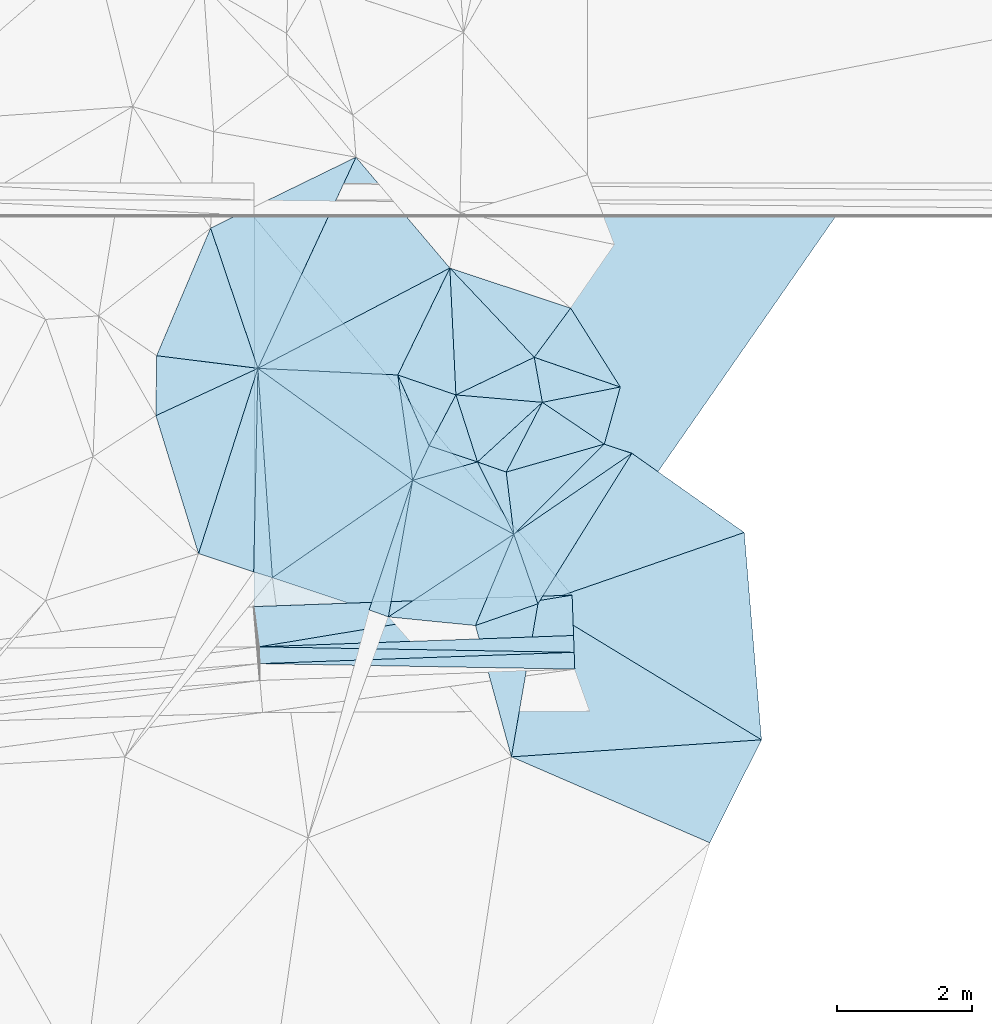
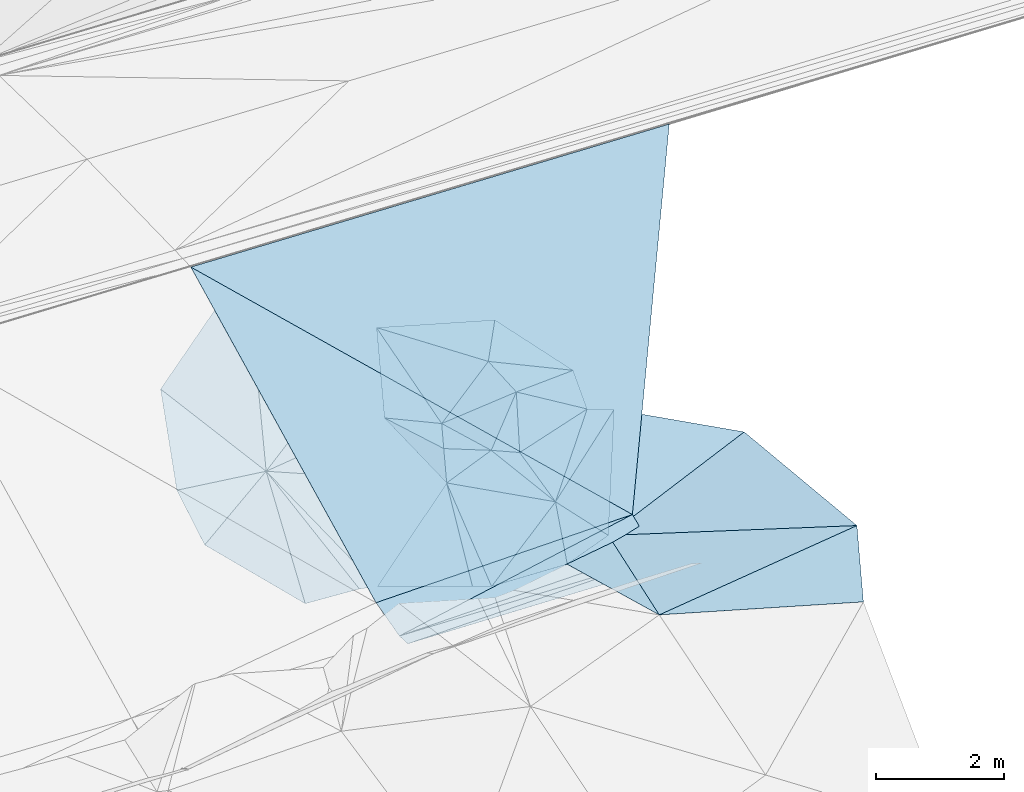
# One storey, part 105 of 275: 46 plates.
"""IFC2X3 building model written with IfcOpenShell, lengths in millimetres."""

from ifc_helpers import new_model, si_unit, frame, origin_with_axes, place, context, subcontext, project, spatial, polyline, outline, extrude, material, type_object, element, save


model = new_model("IFC2X3")

# Units and contexts
model_context = context("Model", 3, precision=1e-05, world=origin_with_axes())
body_context = subcontext(model_context, "Body", "Model", "MODEL_VIEW")
ifc_project = project(units=[si_unit("LENGTHUNIT", "METRE", prefix="MILLI"), si_unit("AREAUNIT", "SQUARE_METRE"), si_unit("VOLUMEUNIT", "CUBIC_METRE"), si_unit("MASSUNIT", "GRAM", prefix="KILO"), si_unit("TIMEUNIT", "SECOND"), si_unit("PLANEANGLEUNIT", "RADIAN"), si_unit("SOLIDANGLEUNIT", "STERADIAN"), si_unit("THERMODYNAMICTEMPERATUREUNIT", "DEGREE_CELSIUS"), si_unit("LUMINOUSINTENSITYUNIT", "LUMEN")], contexts=[model_context])

# Site, building, storey
site_placement = place(None, origin_with_axes())
site = spatial("IfcSite", under=ifc_project, at=site_placement, CompositionType="ELEMENT")
building_placement = place(site_placement, origin_with_axes())
building = spatial("IfcBuilding", under=site, at=building_placement, Name="Undefined", CompositionType="ELEMENT")
storey_placement = place(building_placement, origin_with_axes())
storey = spatial("IfcBuildingStorey", under=building, at=storey_placement, Name="Undefined", CompositionType="ELEMENT", Elevation=0.0)

# Plates
ifc_material = material()
plate_type_1 = type_object("IfcPlateType", PredefinedType="NOTDEFINED")
for number, where, z_axis, x_axis, name in (
    (1, (-34071.6223513532, 53401.6972829406, 44876.9950661578), (-0.0160094213727452, -0.000576917723859668, -0.999871674562916), (0.999223107997821, 0.0360075830405847, -0.0160198129436686), "00_PR"),
    (2, (-34080.6255523852, 53651.5352707034, 44876.9950644375), (-0.0160094213727452, -0.000576917723859668, -0.999871674562916), (0.999223107997821, 0.0360075830405847, -0.0160198129436686), "00_PR"),
    (3, (-29400.480336561, 53570.0245866541, 44802.1060646586), (-0.0160094213727452, -0.000576917723859668, -0.999871674562916), (-0.999223107998599, -0.0360075830192284, 0.0160198129431634), "00_PR"),
):
    element("IfcPlate", number, at=place(storey_placement, frame(where, z_axis=z_axis, x_axis=x_axis)), inside=storey, type_object=plate_type_1, material=ifc_material, Name=name, context=body_context, shape_type="SweptSolid", body=[
        extrude(outline(polyline([(0.0, 0.0), (4674.77392578125, -1.64072844199836e-08), (4674.77392578125, 250.000152587891), (0.0, 0.0)])), frame((-8.85201319254618e-08, 2.18876761149539e-07, -0.5000001331573), z_axis=(0.0, 0.0, 1.0), x_axis=(1.0, 0.0, 0.0)), (0.0, 0.0, 1.0), 1.0),
    ])
plate_type_2 = type_object("IfcPlateType", PredefinedType="NOTDEFINED")
plate_1_placement = place(storey_placement, frame((-34980.2329923072, 55035.6224155417, 44969.5172339417), z_axis=(0.231715827225218, 0.118649041809112, -0.965520678334293), x_axis=(-0.294650401531894, 0.954469308654738, 0.0465776739784269)))
element("IfcPlate", 4, at=plate_1_placement, inside=storey, type_object=plate_type_2, material=ifc_material, Name="00", context=body_context, shape_type="SweptSolid", body=[
    extrude(outline(polyline([(0.0, 0.0), (2146.95141601563, -6.11908035352826e-09), (2392.13623046875, 1712.36218261719), (0.0, 0.0)])), frame((-8.85201319254618e-08, 2.18876761149539e-07, -0.5000001331573), z_axis=(0.0, 0.0, 1.0), x_axis=(1.0, 0.0, 0.0)), (0.0, 0.0, 1.0), 1.0),
])
plate_type_3 = type_object("IfcPlateType", PredefinedType="NOTDEFINED")
plate_2_placement = place(storey_placement, frame((-28543.1043825455, 56525.7265106292, 45519.5109293594), z_axis=(0.115885451345455, 0.172720075435549, -0.978130020860212), x_axis=(-0.518015561419789, -0.829724566261981, -0.207887042088507)))
element("IfcPlate", 5, at=plate_2_placement, inside=storey, type_object=plate_type_3, material=ifc_material, Name="00", context=body_context, shape_type="SweptSolid", body=[
    extrude(outline(polyline([(0.0, 0.0), (2693.7705078125, 6.66477717459202e-09), (1992.96850585938, 851.279296875), (0.0, 0.0)])), frame((-8.85201319254618e-08, 2.18876761149539e-07, -0.5000001331573), z_axis=(0.0, 0.0, 1.0), x_axis=(1.0, 0.0, 0.0)), (0.0, 0.0, 1.0), 1.0),
])
plate_type_4 = type_object("IfcPlateType", PredefinedType="NOTDEFINED")
plate_3_placement = place(storey_placement, frame((-31246.6210959836, 59277.6440215739, 46359.541500599), z_axis=(0.17469677616327, 0.358633115088476, -0.916986000525687), x_axis=(0.678853557676361, -0.718442221787708, -0.151652962987508)))
element("IfcPlate", 6, at=plate_3_placement, inside=storey, type_object=plate_type_4, material=ifc_material, Name="00", context=body_context, shape_type="SweptSolid", body=[
    extrude(outline(polyline([(0.0, 0.0), (1846.32067871094, 2.47382558882236e-10), (1524.1123046875, 1324.94592285156), (0.0, 0.0)])), frame((-8.85201319254618e-08, 2.18876761149539e-07, -0.5000001331573), z_axis=(0.0, 0.0, 1.0), x_axis=(1.0, 0.0, 0.0)), (0.0, 0.0, 1.0), 1.0),
])
plate_type_5 = type_object("IfcPlateType", PredefinedType="NOTDEFINED")
plate_4_placement = place(storey_placement, frame((-29872.8224917118, 57282.821722104, 45859.5295280581), z_axis=(-0.0500565715002064, 0.334876283704204, -0.94093156725774), x_axis=(0.80520797630461, -0.54383905544036, -0.23638780990815)))
element("IfcPlate", 7, at=plate_4_placement, inside=storey, type_object=plate_type_5, material=ifc_material, Name="00", context=body_context, shape_type="SweptSolid", body=[
    extrude(outline(polyline([(0.0, 0.0), (1142.19091796875, 2.5465851649642e-09), (211.085556030273, 1196.67993164063), (0.0, 0.0)])), frame((-8.85201319254618e-08, 2.18876761149539e-07, -0.5000001331573), z_axis=(0.0, 0.0, 1.0), x_axis=(1.0, 0.0, 0.0)), (0.0, 0.0, 1.0), 1.0),
])
plate_type_6 = type_object("IfcPlateType", PredefinedType="NOTDEFINED")
plate_5_placement = place(storey_placement, frame((-34080.6327561477, 53651.7587413823, 44877.0478344557), z_axis=(-0.030423128041603, 0.446361798580259, -0.894335271611469), x_axis=(0.985509466993373, 0.162771131022706, 0.0477142470550187)))
element("IfcPlate", 8, at=plate_5_placement, inside=storey, type_object=plate_type_6, material=ifc_material, Name="00_PR", context=body_context, shape_type="SweptSolid", body=[
    extrude(outline(polyline([(0.0, 0.0), (4717.89892578125, -4.75847627967596e-09), (4627.2802734375, 664.671203613281), (0.0, 0.0)])), frame((-8.85201319254618e-08, 2.18876761149539e-07, -0.5000001331573), z_axis=(0.0, 0.0, 1.0), x_axis=(1.0, 0.0, 0.0)), (0.0, 0.0, 1.0), 1.0),
])
plate_type_7 = type_object("IfcPlateType", PredefinedType="NOTDEFINED")
plate_6_placement = place(storey_placement, frame((-34158.2967206193, 54249.3492435354, 45177.0475667269), z_axis=(-0.0302235307072089, 0.445309090165948, -0.894866667390828), x_axis=(0.999226135317883, 0.0360075680378038, -0.0158298939254558)))
element("IfcPlate", 9, at=plate_6_placement, inside=storey, type_object=plate_type_7, material=ifc_material, Name="00_PR", context=body_context, shape_type="SweptSolid", body=[
    extrude(outline(polyline([(0.0, 0.0), (4730.859375, 3.53611540049315e-09), (60.8351287841797, 670.4072265625), (0.0, 0.0)])), frame((-8.85201319254618e-08, 2.18876761149539e-07, -0.5000001331573), z_axis=(0.0, 0.0, 1.0), x_axis=(1.0, 0.0, 0.0)), (0.0, 0.0, 1.0), 1.0),
])
plate_type_8 = type_object("IfcPlateType", PredefinedType="NOTDEFINED")
plate_7_placement = place(storey_placement, frame((-29993.2335942096, 57951.158694528, 46079.5386960998), z_axis=(0.186993604006118, 0.337419051599231, -0.922595130964108), x_axis=(0.168841462637769, -0.936224389979154, -0.308182498047017)))
element("IfcPlate", 10, at=plate_7_placement, inside=storey, type_object=plate_type_8, material=ifc_material, Name="00", context=body_context, shape_type="SweptSolid", body=[
    extrude(outline(polyline([(0.0, 0.0), (713.862731933594, 2.06091499421746e-09), (461.713409423828, 1283.01232910156), (0.0, 0.0)])), frame((-8.85201319254618e-08, 2.18876761149539e-07, -0.5000001331573), z_axis=(0.0, 0.0, 1.0), x_axis=(1.0, 0.0, 0.0)), (0.0, 0.0, 1.0), 1.0),
])
plate_type_9 = type_object("IfcPlateType", PredefinedType="NOTDEFINED")
plate_8_placement = place(storey_placement, frame((-25520.841440914, 60038.5762941527, 47779.2089931569), z_axis=(-0.030271263853326, 0.447010042706358, -0.894016595094511), x_axis=(-0.531978152859471, -0.764430853825153, -0.364204221008452)))
element("IfcPlate", 11, at=plate_8_placement, inside=storey, type_object=plate_type_9, material=ifc_material, Name="00_PR", context=body_context, shape_type="SweptSolid", body=[
    extrude(outline(polyline([(0.0, 0.0), (7350.4091796875, 4.61295712739229e-09), (4487.78076171875, 7385.48583984375), (0.0, 0.0)])), frame((-8.85201319254618e-08, 2.18876761149539e-07, -0.5000001331573), z_axis=(0.0, 0.0, 1.0), x_axis=(1.0, 0.0, 0.0)), (0.0, 0.0, 1.0), 1.0),
])
plate_type_10 = type_object("IfcPlateType", PredefinedType="NOTDEFINED")
plate_9_placement = place(storey_placement, frame((-29431.0984697867, 54419.696831974, 45102.1589926173), z_axis=(-0.030271263853326, 0.447010042706358, -0.894016595094511), x_axis=(-0.99922613531855, -0.0360075680171456, 0.0158298939303357)))
element("IfcPlate", 12, at=plate_9_placement, inside=storey, type_object=plate_type_10, material=ifc_material, Name="00_PR", context=body_context, shape_type="SweptSolid", body=[
    extrude(outline(polyline([(0.0, 0.0), (4730.859375, 3.53611540049315e-09), (4567.87939453125, 6471.05224609375), (0.0, 0.0)])), frame((-8.85201319254618e-08, 2.18876761149539e-07, -0.5000001331573), z_axis=(0.0, 0.0, 1.0), x_axis=(1.0, 0.0, 0.0)), (0.0, 0.0, 1.0), 1.0),
])
plate_type_11 = type_object("IfcPlateType", PredefinedType="NOTDEFINED")
plate_10_placement = place(storey_placement, frame((-35612.9328880518, 57085.0067696832, 45069.5641642361), z_axis=(0.032064467690948, 0.489062705662112, -0.871659073171473), x_axis=(0.0106595673825334, 0.871890578416482, 0.489584714724417)))
element("IfcPlate", 13, at=plate_10_placement, inside=storey, type_object=plate_type_11, material=ifc_material, Name="00", context=body_context, shape_type="SweptSolid", body=[
    extrude(outline(polyline([(0.0, 0.0), (1021.27374267578, 1.38970790430903e-09), (849.1357421875, 1507.07287597656), (0.0, 0.0)])), frame((-8.85201319254618e-08, 2.18876761149539e-07, -0.5000001331573), z_axis=(0.0, 0.0, 1.0), x_axis=(1.0, 0.0, 0.0)), (0.0, 0.0, 1.0), 1.0),
])
plate_type_12 = type_object("IfcPlateType", PredefinedType="NOTDEFINED")
plate_11_placement = place(storey_placement, frame((-30837.0909171989, 56397.3492246473, 45619.549087317), z_axis=(-0.00977081936013433, 0.432013518414456, -0.901814199819561), x_axis=(0.412533971428699, -0.81979027545528, -0.397189660850105)))
element("IfcPlate", 14, at=plate_11_placement, inside=storey, type_object=plate_type_12, material=ifc_material, Name="00", context=body_context, shape_type="SweptSolid", body=[
    extrude(outline(polyline([(0.0, 0.0), (1309.1982421875, -7.18500814400613e-11), (-126.03133392334, 999.107666015625), (0.0, 0.0)])), frame((-8.85201319254618e-08, 2.18876761149539e-07, -0.5000001331573), z_axis=(0.0, 0.0, 1.0), x_axis=(1.0, 0.0, 0.0)), (0.0, 0.0, 1.0), 1.0),
])
plate_type_13 = type_object("IfcPlateType", PredefinedType="NOTDEFINED")
plate_12_placement = place(storey_placement, frame((-31799.0690266377, 56125.0029589396, 45499.5235800785), z_axis=(0.172393046456249, 0.249797371474113, -0.952828374230196), x_axis=(-0.810236116695947, 0.586061201736634, 0.00705003691362873)))
element("IfcPlate", 15, at=plate_12_placement, inside=storey, type_object=plate_type_13, material=ifc_material, Name="00", context=body_context, shape_type="SweptSolid", body=[
    extrude(outline(polyline([(0.0, 0.0), (2836.86450195313, 8.00355337560177e-10), (1098.57202148438, 1193.87585449219), (0.0, 0.0)])), frame((-8.85201319254618e-08, 2.18876761149539e-07, -0.5000001331573), z_axis=(0.0, 0.0, 1.0), x_axis=(1.0, 0.0, 0.0)), (0.0, 0.0, 1.0), 1.0),
])
plate_type_14 = type_object("IfcPlateType", PredefinedType="NOTDEFINED")
plate_13_placement = place(storey_placement, frame((-29872.8782961631, 57282.7953500312, 45859.527165874), z_axis=(-0.161665226520052, 0.282132074219349, -0.945656305023611), x_axis=(-0.168841462640882, 0.936224389976332, 0.308182498053884)))
element("IfcPlate", 16, at=plate_13_placement, inside=storey, type_object=plate_type_14, material=ifc_material, Name="00", context=body_context, shape_type="SweptSolid", body=[
    extrude(outline(polyline([(0.0, 0.0), (713.862731933594, 2.06091499421746e-09), (-22.6934375762939, 1185.95324707031), (0.0, 0.0)])), frame((-8.85201319254618e-08, 2.18876761149539e-07, -0.5000001331573), z_axis=(0.0, 0.0, 1.0), x_axis=(1.0, 0.0, 0.0)), (0.0, 0.0, 1.0), 1.0),
])
plate_type_15 = type_object("IfcPlateType", PredefinedType="NOTDEFINED")
plate_14_placement = place(storey_placement, frame((-31555.6123544421, 56637.1429635252, 45759.5175400277), z_axis=(-0.262156579429736, -0.0149853308560227, -0.964908994527896), x_axis=(-0.402506454696642, 0.910451628016118, 0.0952175770030915)))
element("IfcPlate", 17, at=plate_14_placement, inside=storey, type_object=plate_type_15, material=ifc_material, Name="00", context=body_context, shape_type="SweptSolid", body=[
    extrude(outline(polyline([(0.0, 0.0), (1155.24890136719, -3.13593773171306e-09), (516.165832519531, 691.211120605469), (0.0, 0.0)])), frame((-8.85201319254618e-08, 2.18876761149539e-07, -0.5000001331573), z_axis=(0.0, 0.0, 1.0), x_axis=(1.0, 0.0, 0.0)), (0.0, 0.0, 1.0), 1.0),
])
plate_type_16 = type_object("IfcPlateType", PredefinedType="NOTDEFINED")
plate_15_placement = place(storey_placement, frame((-32020.2825198391, 57689.0805906542, 45869.5583962413), z_axis=(0.387780182659138, 0.263802896562849, -0.883195653126699), x_axis=(0.402506454700626, -0.910451628012649, -0.0952175770194189)))
element("IfcPlate", 18, at=plate_15_placement, inside=storey, type_object=plate_type_16, material=ifc_material, Name="00", context=body_context, shape_type="SweptSolid", body=[
    extrude(outline(polyline([(0.0, 0.0), (1155.24890136719, -3.13593773171306e-09), (1548.32434082031, 484.65625), (0.0, 0.0)])), frame((-8.85201319254618e-08, 2.18876761149539e-07, -0.5000001331573), z_axis=(0.0, 0.0, 1.0), x_axis=(1.0, 0.0, 0.0)), (0.0, 0.0, 1.0), 1.0),
])
plate_type_17 = type_object("IfcPlateType", PredefinedType="NOTDEFINED")
plate_16_placement = place(storey_placement, frame((-29938.5434387831, 54290.5466241133, 44959.5011846774), z_axis=(0.0679457742926506, -0.0117852113256416, -0.997619406662572), x_axis=(0.852560848259481, -0.518670619471749, 0.0641933681299427)))
element("IfcPlate", 19, at=plate_16_placement, inside=storey, type_object=plate_type_17, material=ifc_material, Name="00", context=body_context, shape_type="SweptSolid", body=[
    extrude(outline(polyline([(0.0, 0.0), (3894.4833984375, -1.54250301420689e-09), (843.038696289063, 2148.04223632813), (0.0, 0.0)])), frame((-8.85201319254618e-08, 2.18876761149539e-07, -0.5000001331573), z_axis=(0.0, 0.0, 1.0), x_axis=(1.0, 0.0, 0.0)), (0.0, 0.0, 1.0), 1.0),
])
plate_type_18 = type_object("IfcPlateType", PredefinedType="NOTDEFINED")
plate_17_placement = place(storey_placement, frame((-33882.4227468981, 54679.1145902745, 45129.5044240022), z_axis=(0.0387548904285732, 0.127038372737867, -0.991140408983502), x_axis=(-0.956482750278148, 0.291788876450681, -1.37765423370374e-10)))
element("IfcPlate", 20, at=plate_17_placement, inside=storey, type_object=plate_type_18, material=ifc_material, Name="00", context=body_context, shape_type="SweptSolid", body=[
    extrude(outline(polyline([(0.0, 0.0), (290.688842773438, 1.68802216649055e-09), (1112.87377929688, 2936.34326171875), (0.0, 0.0)])), frame((-8.85201319254618e-08, 2.18876761149539e-07, -0.5000001331573), z_axis=(0.0, 0.0, 1.0), x_axis=(1.0, 0.0, 0.0)), (0.0, 0.0, 1.0), 1.0),
])
plate_type_19 = type_object("IfcPlateType", PredefinedType="NOTDEFINED")
plate_18_placement = place(storey_placement, frame((-28715.9440555796, 57509.9521868098, 45729.5158720224), z_axis=(-0.148321172531613, 0.201257457141071, -0.968243908178077), x_axis=(-0.265959535325341, -0.951120407948406, -0.156956985042354)))
element("IfcPlate", 21, at=plate_18_placement, inside=storey, type_object=plate_type_19, material=ifc_material, Name="00", context=body_context, shape_type="SweptSolid", body=[
    extrude(outline(polyline([(0.0, 0.0), (891.964111328125, 1.89174897968769e-09), (503.383483886719, 1074.06005859375), (0.0, 0.0)])), frame((-8.85201319254618e-08, 2.18876761149539e-07, -0.5000001331573), z_axis=(0.0, 0.0, 1.0), x_axis=(1.0, 0.0, 0.0)), (0.0, 0.0, 1.0), 1.0),
])
plate_type_20 = type_object("IfcPlateType", PredefinedType="NOTDEFINED")
plate_19_placement = place(storey_placement, frame((-30332.9176918458, 52016.9439876698, 44959.5002985326), z_axis=(0.034358207311153, -0.0059594393241124, -0.999391814391786), x_axis=(-0.264167777671627, 0.964362683207838, -0.014832413027322)))
element("IfcPlate", 22, at=plate_19_placement, inside=storey, type_object=plate_type_20, material=ifc_material, Name="00", context=body_context, shape_type="SweptSolid", body=[
    extrude(outline(polyline([(0.0, 0.0), (2022.59729003906, 4.78576112072915e-09), (2088.40380859375, 981.513916015625), (0.0, 0.0)])), frame((-8.85201319254618e-08, 2.18876761149539e-07, -0.5000001331573), z_axis=(0.0, 0.0, 1.0), x_axis=(1.0, 0.0, 0.0)), (0.0, 0.0, 1.0), 1.0),
])
plate_type_21 = type_object("IfcPlateType", PredefinedType="NOTDEFINED")
plate_20_placement = place(storey_placement, frame((-30297.0038484308, 55323.9301315374, 45099.5042664596), z_axis=(-0.0131219612474929, 0.129777470937373, -0.991456313798101), x_axis=(0.325058116487336, -0.937131873484525, -0.126968785947929)))
element("IfcPlate", 23, at=plate_20_placement, inside=storey, type_object=plate_type_21, material=ifc_material, Name="00", context=body_context, shape_type="SweptSolid", body=[
    extrude(outline(polyline([(0.0, 0.0), (1102.63317871094, 3.34148353431374e-09), (1107.34924316406, 983.706115722656), (0.0, 0.0)])), frame((-8.85201319254618e-08, 2.18876761149539e-07, -0.5000001331573), z_axis=(0.0, 0.0, 1.0), x_axis=(1.0, 0.0, 0.0)), (0.0, 0.0, 1.0), 1.0),
])
plate_type_22 = type_object("IfcPlateType", PredefinedType="NOTDEFINED")
plate_21_placement = place(storey_placement, frame((-30297.0144486195, 55324.0522393265, 45099.5365960298), z_axis=(-0.0343239097851806, 0.373991142176109, -0.926796900507802), x_axis=(0.686217759688717, 0.683011093540066, 0.250201983183592)))
element("IfcPlate", 24, at=plate_21_placement, inside=storey, type_object=plate_type_22, material=ifc_material, Name="00", context=body_context, shape_type="SweptSolid", body=[
    extrude(outline(polyline([(0.0, 0.0), (1958.41772460938, -1.04191713035107e-08), (2129.42309570313, 402.687408447266), (0.0, 0.0)])), frame((-8.85201319254618e-08, 2.18876761149539e-07, -0.5000001331573), z_axis=(0.0, 0.0, 1.0), x_axis=(1.0, 0.0, 0.0)), (0.0, 0.0, 1.0), 1.0),
])
plate_type_23 = type_object("IfcPlateType", PredefinedType="NOTDEFINED")
plate_22_placement = place(storey_placement, frame((-29872.844196903, 57282.8312776393, 45859.5347103891), z_axis=(-0.0934648893557102, 0.353987605271007, -0.930568154286521), x_axis=(-0.442019326439454, -0.852250524278567, -0.279799855112398)))
element("IfcPlate", 25, at=plate_22_placement, inside=storey, type_object=plate_type_23, material=ifc_material, Name="00", context=body_context, shape_type="SweptSolid", body=[
    extrude(outline(polyline([(0.0, 0.0), (1215.154296875, 9.67702362686396e-10), (1248.07189941406, 462.511016845703), (0.0, 0.0)])), frame((-8.85201319254618e-08, 2.18876761149539e-07, -0.5000001331573), z_axis=(0.0, 0.0, 1.0), x_axis=(1.0, 0.0, 0.0)), (0.0, 0.0, 1.0), 1.0),
])
plate_type_24 = type_object("IfcPlateType", PredefinedType="NOTDEFINED")
plate_23_placement = place(storey_placement, frame((-31799.1649176112, 56125.1079701196, 45499.5560936725), z_axis=(-0.0193872732003786, 0.459818773635412, -0.887801120212337), x_axis=(0.390491087492998, 0.820924052354663, 0.41665382616044)))
element("IfcPlate", 26, at=plate_23_placement, inside=storey, type_object=plate_type_24, material=ifc_material, Name="00", context=body_context, shape_type="SweptSolid", body=[
    extrude(outline(polyline([(0.0, 0.0), (624.019226074219, -1.16415321826935e-09), (649.1787109375, 769.848693847656), (0.0, 0.0)])), frame((-8.85201319254618e-08, 2.18876761149539e-07, -0.5000001331573), z_axis=(0.0, 0.0, 1.0), x_axis=(1.0, 0.0, 0.0)), (0.0, 0.0, 1.0), 1.0),
])
plate_type_25 = type_object("IfcPlateType", PredefinedType="NOTDEFINED")
plate_24_placement = place(storey_placement, frame((-31157.0604582972, 57392.9767792765, 45639.535739207), z_axis=(-0.127749616233246, 0.348638911162115, -0.928510067353044), x_axis=(-0.917247048041618, 0.314586683351554, 0.24432165584902)))
element("IfcPlate", 27, at=plate_24_placement, inside=storey, type_object=plate_type_25, material=ifc_material, Name="00", context=body_context, shape_type="SweptSolid", body=[
    extrude(outline(polyline([(0.0, 0.0), (941.381958007813, 1.84809323400259e-09), (851.089172363281, 1831.40576171875), (0.0, 0.0)])), frame((-8.85201319254618e-08, 2.18876761149539e-07, -0.5000001331573), z_axis=(0.0, 0.0, 1.0), x_axis=(1.0, 0.0, 0.0)), (0.0, 0.0, 1.0), 1.0),
])
plate_type_26 = type_object("IfcPlateType", PredefinedType="NOTDEFINED")
plate_25_placement = place(storey_placement, frame((-30836.998689496, 56397.171140939, 45619.5091446162), z_axis=(0.174683233166714, 0.0758454614691615, -0.981699156577489), x_axis=(-0.30584406469394, 0.951889600103376, 0.0191205990105864)))
element("IfcPlate", 28, at=plate_25_placement, inside=storey, type_object=plate_type_26, material=ifc_material, Name="00", context=body_context, shape_type="SweptSolid", body=[
    extrude(outline(polyline([(0.0, 0.0), (1045.99230957031, -3.76530806533992e-09), (552.585327148438, 1210.88793945313), (0.0, 0.0)])), frame((-8.85201319254618e-08, 2.18876761149539e-07, -0.5000001331573), z_axis=(0.0, 0.0, 1.0), x_axis=(1.0, 0.0, 0.0)), (0.0, 0.0, 1.0), 1.0),
])
plate_type_27 = type_object("IfcPlateType", PredefinedType="NOTDEFINED")
plate_26_placement = place(storey_placement, frame((-31246.6223690448, 59277.5711188677, 46359.5190922211), z_axis=(0.172152296436728, 0.212826567497465, -0.961804782166739), x_axis=(-0.421986904436773, -0.866322963267258, -0.267229444110688)))
element("IfcPlate", 29, at=plate_26_placement, inside=storey, type_object=plate_type_27, material=ifc_material, Name="00", context=body_context, shape_type="SweptSolid", body=[
    extrude(outline(polyline([(0.0, 0.0), (1833.63024902344, -3.9945007301867e-09), (2718.3779296875, 1914.21569824219), (0.0, 0.0)])), frame((-8.85201319254618e-08, 2.18876761149539e-07, -0.5000001331573), z_axis=(0.0, 0.0, 1.0), x_axis=(1.0, 0.0, 0.0)), (0.0, 0.0, 1.0), 1.0),
])
plate_type_28 = type_object("IfcPlateType", PredefinedType="NOTDEFINED")
plate_27_placement = place(storey_placement, frame((-28543.1634057486, 56525.7623032224, 45519.5151463806), z_axis=(-0.00216105641273703, 0.244305952687085, -0.969695793183015), x_axis=(0.808593660471055, -0.570109380555504, -0.145435849942992)))
element("IfcPlate", 30, at=plate_27_placement, inside=storey, type_object=plate_type_28, material=ifc_material, Name="00", context=body_context, shape_type="SweptSolid", body=[
    extrude(outline(polyline([(0.0, 0.0), (2062.76513671875, 4.03088051825762e-09), (227.364715576172, 2684.158203125), (0.0, 0.0)])), frame((-8.85201319254618e-08, 2.18876761149539e-07, -0.5000001331573), z_axis=(0.0, 0.0, 1.0), x_axis=(1.0, 0.0, 0.0)), (0.0, 0.0, 1.0), 1.0),
])
plate_type_29 = type_object("IfcPlateType", PredefinedType="NOTDEFINED")
plate_28_placement = place(storey_placement, frame((-31157.0996040452, 57392.7791756697, 45639.5112767807), z_axis=(-0.206039548297942, -0.0465671964808652, -0.977435011010498), x_axis=(0.305844064688363, -0.951889600105222, -0.0191205990078904)))
element("IfcPlate", 31, at=plate_28_placement, inside=storey, type_object=plate_type_29, material=ifc_material, Name="00", context=body_context, shape_type="SweptSolid", body=[
    extrude(outline(polyline([(0.0, 0.0), (1045.99230957031, -3.76530806533992e-09), (595.128662109375, 624.517333984375), (0.0, 0.0)])), frame((-8.85201319254618e-08, 2.18876761149539e-07, -0.5000001331573), z_axis=(0.0, 0.0, 1.0), x_axis=(1.0, 0.0, 0.0)), (0.0, 0.0, 1.0), 1.0),
])
plate_type_30 = type_object("IfcPlateType", PredefinedType="NOTDEFINED")
plate_29_placement = place(storey_placement, frame((-32159.5392216746, 54096.0529097258, 44879.5226563185), z_axis=(-0.0266288473783911, 0.296453096458841, -0.954676105329584), x_axis=(-0.932743223424971, 0.336135227503008, 0.130396272900325)))
element("IfcPlate", 32, at=plate_29_placement, inside=storey, type_object=plate_type_30, material=ifc_material, Name="00", context=body_context, shape_type="SweptSolid", body=[
    extrude(outline(polyline([(0.0, 0.0), (306.757232666016, -1.55705492943525e-09), (426.721801757813, 2109.24365234375), (0.0, 0.0)])), frame((-8.85201319254618e-08, 2.18876761149539e-07, -0.5000001331573), z_axis=(0.0, 0.0, 1.0), x_axis=(1.0, 0.0, 0.0)), (0.0, 0.0, 1.0), 1.0),
])
plate_type_31 = type_object("IfcPlateType", PredefinedType="NOTDEFINED")
plate_30_placement = place(storey_placement, frame((-29452.8161369279, 58682.1520344061, 46239.5312284658), z_axis=(-0.148166693011349, 0.314774458989959, -0.937530624059641), x_axis=(0.499416553395225, -0.794422282441569, -0.345653501870243)))
element("IfcPlate", 33, at=plate_30_placement, inside=storey, type_object=plate_type_31, material=ifc_material, Name="00", context=body_context, shape_type="SweptSolid", body=[
    extrude(outline(polyline([(0.0, 0.0), (1475.46606445313, 1.53340806718916e-09), (366.053833007813, 847.469543457031), (0.0, 0.0)])), frame((-8.85201319254618e-08, 2.18876761149539e-07, -0.5000001331573), z_axis=(0.0, 0.0, 1.0), x_axis=(1.0, 0.0, 0.0)), (0.0, 0.0, 1.0), 1.0),
])
plate_31_placement = place(storey_placement, frame((-34097.5711305559, 57787.5142022689, 45519.5169011792), z_axis=(0.228282070399502, 0.119883374472282, -0.966185941141381), x_axis=(-0.0205936283788782, -0.991573356675683, -0.127899103988695)))
element("IfcPlate", 34, at=plate_31_placement, inside=storey, type_object=plate_type_31, material=ifc_material, Name="00", context=body_context, shape_type="SweptSolid", body=[
    extrude(outline(polyline([(0.0, 0.0), (3049.27856445313, 8.68385541252792e-09), (2817.2236328125, 847.201599121094), (0.0, 0.0)])), frame((-8.85201319254618e-08, 2.18876761149539e-07, -0.5000001331573), z_axis=(0.0, 0.0, 1.0), x_axis=(1.0, 0.0, 0.0)), (0.0, 0.0, 1.0), 1.0),
])
plate_type_32 = type_object("IfcPlateType", PredefinedType="NOTDEFINED")
plate_32_placement = place(storey_placement, frame((-30867.2155301664, 53967.5163633153, 44929.5033039939), z_axis=(0.0487714086623381, 0.103998182826277, -0.993380957974293), x_axis=(-0.994360380544713, 0.0988294884442101, -0.0384729231646143)))
element("IfcPlate", 35, at=plate_32_placement, inside=storey, type_object=plate_type_32, material=ifc_material, Name="00", context=body_context, shape_type="SweptSolid", body=[
    extrude(outline(polyline([(0.0, 0.0), (1299.61535644531, -1.60071067512035e-10), (-439.514678955078, 1414.47058105469), (0.0, 0.0)])), frame((-8.85201319254618e-08, 2.18876761149539e-07, -0.5000001331573), z_axis=(0.0, 0.0, 1.0), x_axis=(1.0, 0.0, 0.0)), (0.0, 0.0, 1.0), 1.0),
])
plate_type_33 = type_object("IfcPlateType", PredefinedType="NOTDEFINED")
plate_33_placement = place(storey_placement, frame((-30297.0331154566, 55324.0681281459, 45099.5444137225), z_axis=(-0.0716555322948431, 0.4057705384382, -0.911161761065024), x_axis=(-0.110654547583171, 0.904637058610428, 0.411566960879802)))
element("IfcPlate", 36, at=plate_33_placement, inside=storey, type_object=plate_type_33, material=ifc_material, Name="00", context=body_context, shape_type="SweptSolid", body=[
    extrude(outline(polyline([(0.0, 0.0), (1020.49005126953, -2.00088834390044e-09), (1263.02062988281, 1496.72277832031), (0.0, 0.0)])), frame((-8.85201319254618e-08, 2.18876761149539e-07, -0.5000001331573), z_axis=(0.0, 0.0, 1.0), x_axis=(1.0, 0.0, 0.0)), (0.0, 0.0, 1.0), 1.0),
])
plate_type_34 = type_object("IfcPlateType", PredefinedType="NOTDEFINED")
plate_34_placement = place(storey_placement, frame((-30297.0326300809, 55324.0681910556, 45099.5444039385), z_axis=(-0.0706864906849778, 0.405897732873993, -0.911180800106321), x_axis=(-0.412533971427496, 0.819790275455501, 0.397189660850899)))
element("IfcPlate", 37, at=plate_34_placement, inside=storey, type_object=plate_type_34, material=ifc_material, Name="00", context=body_context, shape_type="SweptSolid", body=[
    extrude(outline(polyline([(0.0, 0.0), (1309.1982421875, -7.18500814400613e-11), (970.212158203125, 316.367553710938), (0.0, 0.0)])), frame((-8.85201319254618e-08, 2.18876761149539e-07, -0.5000001331573), z_axis=(0.0, 0.0, 1.0), x_axis=(1.0, 0.0, 0.0)), (0.0, 0.0, 1.0), 1.0),
])
plate_type_35 = type_object("IfcPlateType", PredefinedType="NOTDEFINED")
plate_35_placement = place(storey_placement, frame((-29993.3248302979, 57951.0952956877, 46079.5112149307), z_axis=(0.00452158433655014, 0.210620921792382, -0.977557355134938), x_axis=(-0.678853557673287, 0.718442221790927, 0.151652962986015)))
element("IfcPlate", 38, at=plate_35_placement, inside=storey, type_object=plate_type_35, material=ifc_material, Name="00", context=body_context, shape_type="SweptSolid", body=[
    extrude(outline(polyline([(0.0, 0.0), (1846.32067871094, 2.47382558882236e-10), (182.471008300781, 904.933349609375), (0.0, 0.0)])), frame((-8.85201319254618e-08, 2.18876761149539e-07, -0.5000001331573), z_axis=(0.0, 0.0, 1.0), x_axis=(1.0, 0.0, 0.0)), (0.0, 0.0, 1.0), 1.0),
])
plate_type_36 = type_object("IfcPlateType", PredefinedType="NOTDEFINED")
plate_36_placement = place(storey_placement, frame((-32641.5883641501, 60924.2651052192, 47069.5482344717), z_axis=(0.0433864236057657, 0.426347238014123, -0.903518483974971), x_axis=(0.614005751058168, -0.724792357072155, -0.312526761729753)))
element("IfcPlate", 39, at=plate_36_placement, inside=storey, type_object=plate_type_36, material=ifc_material, Name="00", context=body_context, shape_type="SweptSolid", body=[
    extrude(outline(polyline([(0.0, 0.0), (2271.80541992188, -3.53247742168605e-09), (1863.75988769531, 3299.5908203125), (0.0, 0.0)])), frame((-8.85201319254618e-08, 2.18876761149539e-07, -0.5000001331573), z_axis=(0.0, 0.0, 1.0), x_axis=(1.0, 0.0, 0.0)), (0.0, 0.0, 1.0), 1.0),
])
plate_type_37 = type_object("IfcPlateType", PredefinedType="NOTDEFINED")
plate_37_placement = place(storey_placement, frame((-34800.2764655648, 59871.440206899, 46069.5165361731), z_axis=(-0.000300126225804456, 0.255099955996867, -0.966914640686884), x_axis=(0.309941837487642, -0.919275738448016, -0.242627644912196)))
element("IfcPlate", 40, at=plate_37_placement, inside=storey, type_object=plate_type_37, material=ifc_material, Name="00", context=body_context, shape_type="SweptSolid", body=[
    extrude(outline(polyline([(0.0, 0.0), (2266.84814453125, 6.02813088335097e-09), (1615.85595703125, 1370.07641601563), (0.0, 0.0)])), frame((-8.85201319254618e-08, 2.18876761149539e-07, -0.5000001331573), z_axis=(0.0, 0.0, 1.0), x_axis=(1.0, 0.0, 0.0)), (0.0, 0.0, 1.0), 1.0),
])
plate_type_38 = type_object("IfcPlateType", PredefinedType="NOTDEFINED")
plate_38_placement = place(storey_placement, frame((-32445.6711509628, 54199.1666657979, 44919.5234462293), z_axis=(-0.0390266410585574, 0.300139280436854, -0.953096707384164), x_axis=(-0.93948016823515, 0.313882137432873, 0.137313572866724)))
element("IfcPlate", 41, at=plate_38_placement, inside=storey, type_object=plate_type_38, material=ifc_material, Name="00", context=body_context, shape_type="SweptSolid", body=[
    extrude(outline(polyline([(0.0, 0.0), (1529.34631347656, 3.12866177409887e-09), (76.7648239135742, 2111.25732421875), (0.0, 0.0)])), frame((-8.85201319254618e-08, 2.18876761149539e-07, -0.5000001331573), z_axis=(0.0, 0.0, 1.0), x_axis=(1.0, 0.0, 0.0)), (0.0, 0.0, 1.0), 1.0),
])
plate_type_39 = type_object("IfcPlateType", PredefinedType="NOTDEFINED")
plate_39_placement = place(storey_placement, frame((-34097.5548284652, 57787.6180740043, 45519.5459570895), z_axis=(0.26088503026386, 0.327630619674018, -0.908073332961741), x_axis=(-0.30994183748582, 0.919275738447936, 0.242627644914825)))
element("IfcPlate", 42, at=plate_39_placement, inside=storey, type_object=plate_type_39, material=ifc_material, Name="00", context=body_context, shape_type="SweptSolid", body=[
    extrude(outline(polyline([(0.0, 0.0), (2266.84814453125, 6.02813088335097e-09), (2808.17236328125, 2544.61547851563), (0.0, 0.0)])), frame((-8.85201319254618e-08, 2.18876761149539e-07, -0.5000001331573), z_axis=(0.0, 0.0, 1.0), x_axis=(1.0, 0.0, 0.0)), (0.0, 0.0, 1.0), 1.0),
])
plate_type_40 = type_object("IfcPlateType", PredefinedType="NOTDEFINED")
plate_40_placement = place(storey_placement, frame((-34097.6426074031, 57787.5191842443, 45519.5060665376), z_axis=(0.0853286284783091, 0.12985120196303, -0.987855095907678), x_axis=(0.810236116693833, -0.586061201739591, -0.00705003691083733)))
element("IfcPlate", 43, at=plate_40_placement, inside=storey, type_object=plate_type_40, material=ifc_material, Name="00", context=body_context, shape_type="SweptSolid", body=[
    extrude(outline(polyline([(0.0, 0.0), (2836.86450195313, 8.00355337560177e-10), (1998.86181640625, 2421.80737304688), (0.0, 0.0)])), frame((-8.85201319254618e-08, 2.18876761149539e-07, -0.5000001331573), z_axis=(0.0, 0.0, 1.0), x_axis=(1.0, 0.0, 0.0)), (0.0, 0.0, 1.0), 1.0),
])
plate_type_41 = type_object("IfcPlateType", PredefinedType="NOTDEFINED")
plate_41_placement = place(storey_placement, frame((-31799.1999671204, 56125.0308427654, 45499.5260155065), z_axis=(-0.0894859646609816, 0.305564169669768, -0.947957172209124), x_axis=(0.85899325808243, -0.45805077733397, -0.228735803827642)))
element("IfcPlate", 44, at=plate_41_placement, inside=storey, type_object=plate_type_41, material=ifc_material, Name="00", context=body_context, shape_type="SweptSolid", body=[
    extrude(outline(polyline([(0.0, 0.0), (1748.74243164063, -3.29600879922509e-09), (761.633056640625, 2012.6884765625), (0.0, 0.0)])), frame((-8.85201319254618e-08, 2.18876761149539e-07, -0.5000001331573), z_axis=(0.0, 0.0, 1.0), x_axis=(1.0, 0.0, 0.0)), (0.0, 0.0, 1.0), 1.0),
])
plate_type_42 = type_object("IfcPlateType", PredefinedType="NOTDEFINED")
plate_42_placement = place(storey_placement, frame((-26618.2528806192, 52270.6034634302, 45209.5016682623), z_axis=(0.0811306040767492, 0.0100068287698604, -0.996653243841665), x_axis=(-0.852560848268427, 0.518670619460089, -0.0641933681053396)))
element("IfcPlate", 45, at=plate_42_placement, inside=storey, type_object=plate_type_42, material=ifc_material, Name="00", context=body_context, shape_type="SweptSolid", body=[
    extrude(outline(polyline([(0.0, 0.0), (3894.4833984375, -1.54250301420689e-09), (1815.41418457031, 2500.17431640625), (0.0, 0.0)])), frame((-8.85201319254618e-08, 2.18876761149539e-07, -0.5000001331573), z_axis=(0.0, 0.0, 1.0), x_axis=(1.0, 0.0, 0.0)), (0.0, 0.0, 1.0), 1.0),
])
plate_type_43 = type_object("IfcPlateType", PredefinedType="NOTDEFINED")
plate_43_placement = place(storey_placement, frame((-27384.8118680618, 50740.0127957951, 44949.5056961278), z_axis=(0.057016985592292, 0.139371100778477, -0.98859736982341), x_axis=(-0.91760837476935, 0.397473499248957, 0.00311254685773576)))
element("IfcPlate", 46, at=plate_43_placement, inside=storey, type_object=plate_type_43, material=ifc_material, Name="00", context=body_context, shape_type="SweptSolid", body=[
    extrude(outline(polyline([(0.0, 0.0), (3212.80249023438, -8.65838956087828e-10), (-94.1856842041016, 1728.93872070313), (0.0, 0.0)])), frame((-8.85201319254618e-08, 2.18876761149539e-07, -0.5000001331573), z_axis=(0.0, 0.0, 1.0), x_axis=(1.0, 0.0, 0.0)), (0.0, 0.0, 1.0), 1.0),
])

save(model, "model.ifc")
